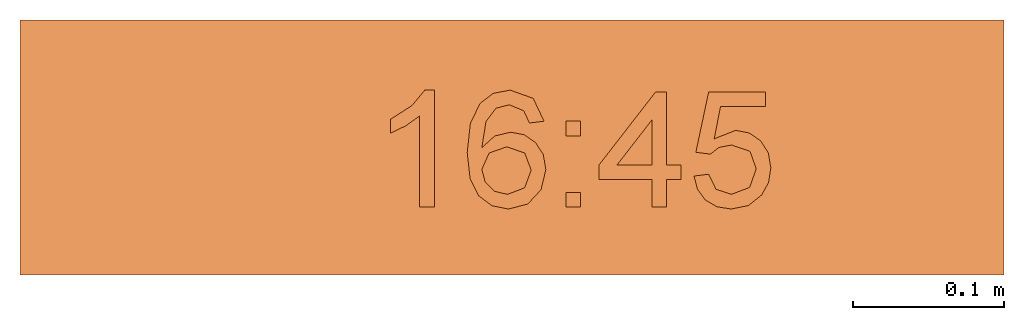
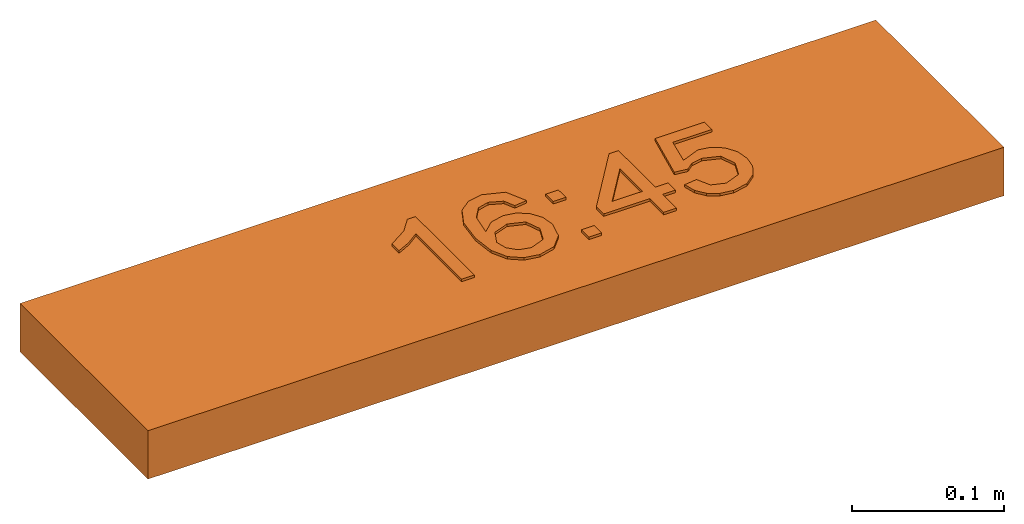
# One storey: 1 proxy.
"""IFC2X3 building model written with IfcOpenShell, lengths in millimetres."""

from ifc_helpers import new_model, entity, si_unit, converted_unit, derived_unit, direction, frame, origin, origin_2d_with_axis, place, context, subcontext, project, spatial, polyline, rectangle, outline, extrude, source, transform, mapped, material, material_list, type_object, type_shapes, element, save


model = new_model("IFC2X3")

# Units and contexts
model_context = context("Model", 3, precision=0.01, world=origin(), true_north=direction((6.12303176911189e-17, 1.0)))
body_context = subcontext(model_context, "Body", "Model", "MODEL_VIEW")
ifc_project = project(units=[si_unit("LENGTHUNIT", "METRE", prefix="MILLI"), si_unit("AREAUNIT", "SQUARE_METRE"), si_unit("VOLUMEUNIT", "CUBIC_METRE"), converted_unit("PLANEANGLEUNIT", "DEGREE", entity("IfcRatioMeasure", 0.0174532925199433), si_unit("PLANEANGLEUNIT", "RADIAN"), dimensions=[0, 0, 0, 0, 0, 0, 0]), si_unit("MASSUNIT", "GRAM", prefix="KILO"), derived_unit("MASSDENSITYUNIT", [(si_unit("MASSUNIT", "GRAM", prefix="KILO"), 1), (si_unit("LENGTHUNIT", "METRE"), -3)]), derived_unit("MOMENTOFINERTIAUNIT", [(si_unit("LENGTHUNIT", "METRE"), 4)]), si_unit("TIMEUNIT", "SECOND"), si_unit("FREQUENCYUNIT", "HERTZ"), si_unit("THERMODYNAMICTEMPERATUREUNIT", "DEGREE_CELSIUS"), derived_unit("THERMALTRANSMITTANCEUNIT", [(si_unit("MASSUNIT", "GRAM", prefix="KILO"), 1), (si_unit("THERMODYNAMICTEMPERATUREUNIT", "KELVIN"), -1), (si_unit("TIMEUNIT", "SECOND"), -3)]), derived_unit("VOLUMETRICFLOWRATEUNIT", [(si_unit("LENGTHUNIT", "METRE"), 3), (si_unit("TIMEUNIT", "SECOND"), -1)]), derived_unit("MASSFLOWRATEUNIT", [(si_unit("MASSUNIT", "GRAM", prefix="KILO"), 1), (si_unit("TIMEUNIT", "SECOND"), -1)]), derived_unit("ROTATIONALFREQUENCYUNIT", [(si_unit("TIMEUNIT", "SECOND"), -1)]), si_unit("ELECTRICCURRENTUNIT", "AMPERE"), si_unit("ELECTRICVOLTAGEUNIT", "VOLT"), si_unit("POWERUNIT", "WATT"), si_unit("FORCEUNIT", "NEWTON", prefix="KILO"), si_unit("ILLUMINANCEUNIT", "LUX"), si_unit("LUMINOUSFLUXUNIT", "LUMEN"), si_unit("LUMINOUSINTENSITYUNIT", "CANDELA"), derived_unit("USERDEFINED", [(si_unit("MASSUNIT", "GRAM", prefix="KILO"), -1), (si_unit("LENGTHUNIT", "METRE"), -2), (si_unit("TIMEUNIT", "SECOND"), 3), (si_unit("LUMINOUSFLUXUNIT", "LUMEN"), 1)]), derived_unit("LINEARVELOCITYUNIT", [(si_unit("LENGTHUNIT", "METRE"), 1), (si_unit("TIMEUNIT", "SECOND"), -1)]), si_unit("PRESSUREUNIT", "PASCAL"), derived_unit("USERDEFINED", [(si_unit("LENGTHUNIT", "METRE"), -2), (si_unit("MASSUNIT", "GRAM", prefix="KILO"), 1), (si_unit("TIMEUNIT", "SECOND"), -2)]), derived_unit("LINEARFORCEUNIT", [(si_unit("MASSUNIT", "GRAM", prefix="KILO"), 1), (si_unit("LENGTHUNIT", "METRE"), 1), (si_unit("TIMEUNIT", "SECOND"), -2), (si_unit("LENGTHUNIT", "METRE"), -1)]), derived_unit("PLANARFORCEUNIT", [(si_unit("MASSUNIT", "GRAM", prefix="KILO"), 1), (si_unit("LENGTHUNIT", "METRE"), 1), (si_unit("TIMEUNIT", "SECOND"), -2), (si_unit("LENGTHUNIT", "METRE"), -2)])], contexts=[model_context])

# Site, building, storey
site_placement = place(None, origin())
site = spatial("IfcSite", under=ifc_project, at=site_placement, CompositionType="ELEMENT")
building_placement = place(site_placement, origin())
building = spatial("IfcBuilding", under=site, at=building_placement, CompositionType="ELEMENT")
storey_placement = place(building_placement, frame((0.0, 0.0, -4200.0)))
storey = spatial("IfcBuildingStorey", under=building, at=storey_placement, CompositionType="ELEMENT", Elevation=-4200.0)

# Proxy
ifc_material_1 = material()
ifc_material_2 = material()
ifc_material_list_1 = material_list([ifc_material_1, ifc_material_2])
ifc_material_list_2 = material_list([ifc_material_1, ifc_material_1, ifc_material_1, ifc_material_1, ifc_material_1, ifc_material_1, ifc_material_2])
building_element_proxy_type = type_object("IfcBuildingElementProxyType", PredefinedType="NOTDEFINED", material=ifc_material_list_2)
shared_shape = source(origin(), body_context, "Body", "SweptSolid", [
    extrude(outline(polyline([(-49.33, -13.07), (28.25, -13.07), (28.25, -6.82), (17.92, 1.81), (8.85, 16.03), (-0.31, 16.03), (4.58, 5.82), (11.12, -3.37), (-49.33, -3.37), (-49.33, -13.07)])), frame((-64.58, 9.8, 39.0), z_axis=(0.0, 0.0, 1.0), x_axis=(0.0, 1.0, 0.0)), (0.0, 0.0, 1.0), 2.0),
    extrude(outline(polyline([(2.24, -27.56), (18.98, -27.56), (30.48, -16.05), (33.3, -4.93), (31.01, 5.76), (21.8, 17.16), (5.25, 27.33), (-11.1, 32.95), (-23.97, 32.7), (-33.63, 27.58), (-40.3, 18.57), (-42.77, 5.67), (-37.97, -6.34), (-27.25, -14.95), (-17.53, -17.67), (-8.19, -16.44), (-0.29, -11.87), (5.1, -4.51), (7.35, 6.15), (4.01, 17.19), (18.45, 7.31), (23.59, -2.44), (21.97, -11.36), (14.17, -18.42), (5.29, -18.28), (2.24, -27.56)]), holes=[polyline([(-8.97, 23.33), (-1.26, 14.35), (-2.55, 1.99), (-11.36, -7.0), (-23.39, -6.05), (-32.18, 2.92), (-31.21, 15.1), (-25.58, 22.11), (-17.52, 24.89), (-8.97, 23.33)])]), frame((-2.74, 3.63, 39.0), z_axis=(0.0, 0.0, 1.0), x_axis=(-0.427648602040224, 0.903945060926294, 0.0)), (0.0, 0.0, 1.0), 2.0),
    extrude(rectangle(XDim=9.6969696969697, YDim=9.6969696969697, at=origin_2d_with_axis()), frame((40.61, -34.68, 39.0)), (0.0, 0.0, 1.0), 2.0),
    extrude(rectangle(XDim=9.6969696969697, YDim=9.6969696969697, at=origin_2d_with_axis()), frame((40.61, 12.59, 39.0)), (0.0, 0.0, 1.0), 2.0),
    extrude(outline(polyline([(-0.88, -28.1), (8.82, -28.1), (8.82, -9.92), (18.51, -9.92), (18.51, -0.22), (8.82, -0.22), (8.82, 48.26), (1.54, 48.26), (-36.03, -0.22), (-36.03, -9.92), (-0.88, -9.92), (-0.88, -28.1)]), holes=[polyline([(-0.88, -0.22), (-24.1, -0.22), (-0.88, 29.74), (-0.88, -0.22)])]), frame((93.61, -11.43, 39.0)), (0.0, 0.0, 1.0), 2.0),
    extrude(outline(polyline([(3.28, -28.27), (12.49, -28.27), (20.54, -25.03), (26.82, -18.85), (30.71, -10.03), (31.4, 1.61), (26.9, 11.84), (20.06, 18.38), (11.08, 22.34), (1.04, 23.26), (-7.94, 20.41), (-14.91, 14.48), (-18.92, 6.17), (-17.14, -8.98), (-36.72, 0.52), (-29.08, 29.25), (-38.45, 31.74), (-48.11, -4.57), (-11.63, -23.05), (-7.97, -13.99), (-10.8, -7.6), (-10.24, 1.06), (-3.0, 11.84), (9.17, 12.81), (19.98, 5.45), (21.35, -7.5), (15.51, -16.43), (4.6, -18.59), (3.28, -28.27)])), frame((147.08, -8.49, 39.0), z_axis=(0.0, 0.0, 1.0), x_axis=(0.256974144339772, -0.966418278563088, 0.0)), (0.0, 0.0, 1.0), 2.0),
    extrude(rectangle(XDim=652.0, YDim=169.000000000001, at=origin_2d_with_axis()), frame((0.0, 0.0, 0.0), z_axis=(0.0, 0.0, 1.0), x_axis=(-1.0, 0.0, 0.0)), (0.0, 0.0, 1.0), 38.9999999999999),
])
type_shapes(building_element_proxy_type, [shared_shape])
proxy_placement = place(storey_placement, frame((51787.73, 25711.17, 0.0)))
element("IfcBuildingElementProxy", 1, at=proxy_placement, inside=storey, type_object=building_element_proxy_type, material=ifc_material_list_1, context=body_context, shape_type="MappedRepresentation", body=[
    mapped(shared_shape, transform((0.0, 0.0, 0.0), scale=1.0)),
])

save(model, "model.ifc")
